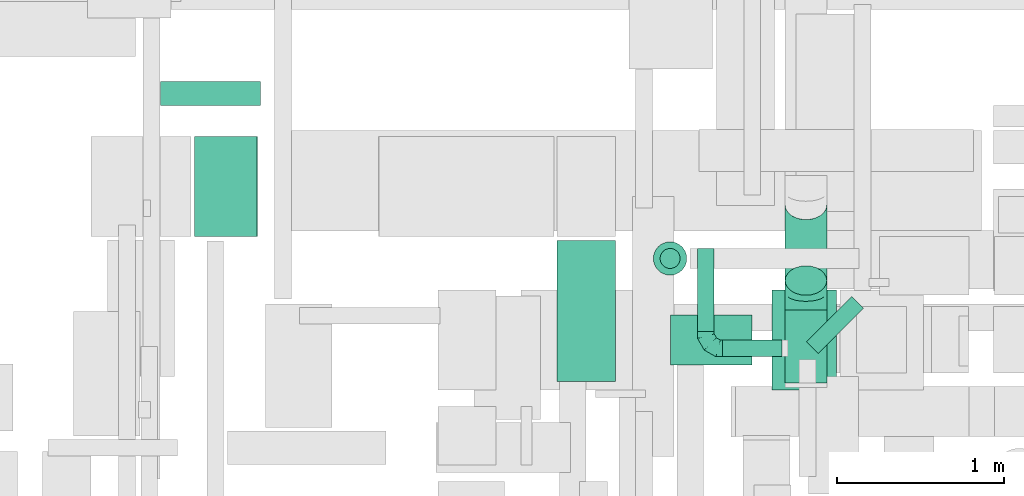
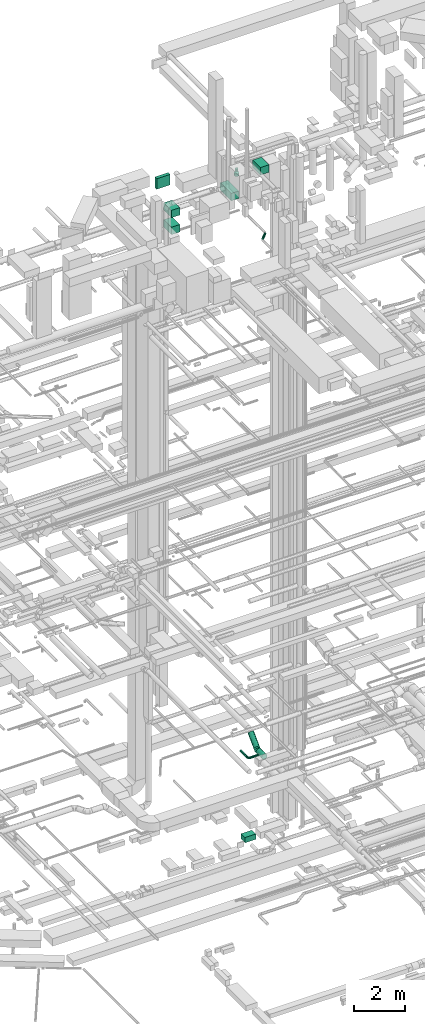
# One storey, part 137 of 337: 13 flow segments, 2 flow fittings.
"""IFC2X3 building model written with IfcOpenShell, lengths in millimetres."""

from ifc_helpers import new_model, entity, si_unit, converted_unit, derived_unit, direction, frame, origin, origin_2d_with_axis, place, context, subcontext, project, spatial, rectangle, circle, extrude, faceted_brep, source, transform, mapped, material, type_object, type_shapes, element, save


model = new_model("IFC2X3")

# Units and contexts
model_context = context("Model", 3, precision=0.01, world=origin(), true_north=direction((6.12303176911189e-17, 1.0)))
body_context = subcontext(model_context, "Body", "Model", "MODEL_VIEW")
ifc_project = project(units=[si_unit("LENGTHUNIT", "METRE", prefix="MILLI"), si_unit("AREAUNIT", "SQUARE_METRE"), si_unit("VOLUMEUNIT", "CUBIC_METRE"), converted_unit("PLANEANGLEUNIT", "DEGREE", entity("IfcRatioMeasure", 0.0174532925199433), si_unit("PLANEANGLEUNIT", "RADIAN"), dimensions=[0, 0, 0, 0, 0, 0, 0]), si_unit("MASSUNIT", "GRAM", prefix="KILO"), derived_unit("MASSDENSITYUNIT", [(si_unit("MASSUNIT", "GRAM", prefix="KILO"), 1), (si_unit("LENGTHUNIT", "METRE"), -3)]), derived_unit("MOMENTOFINERTIAUNIT", [(si_unit("LENGTHUNIT", "METRE"), 4)]), si_unit("TIMEUNIT", "SECOND"), si_unit("FREQUENCYUNIT", "HERTZ"), si_unit("THERMODYNAMICTEMPERATUREUNIT", "DEGREE_CELSIUS"), derived_unit("THERMALTRANSMITTANCEUNIT", [(si_unit("MASSUNIT", "GRAM", prefix="KILO"), 1), (si_unit("THERMODYNAMICTEMPERATUREUNIT", "KELVIN"), -1), (si_unit("TIMEUNIT", "SECOND"), -3)]), derived_unit("VOLUMETRICFLOWRATEUNIT", [(si_unit("LENGTHUNIT", "METRE"), 3), (si_unit("TIMEUNIT", "SECOND"), -1)]), derived_unit("MASSFLOWRATEUNIT", [(si_unit("MASSUNIT", "GRAM", prefix="KILO"), 1), (si_unit("TIMEUNIT", "SECOND"), -1)]), derived_unit("ROTATIONALFREQUENCYUNIT", [(si_unit("TIMEUNIT", "SECOND"), -1)]), si_unit("ELECTRICCURRENTUNIT", "AMPERE"), si_unit("ELECTRICVOLTAGEUNIT", "VOLT"), si_unit("POWERUNIT", "WATT"), si_unit("FORCEUNIT", "NEWTON", prefix="KILO"), si_unit("ILLUMINANCEUNIT", "LUX"), si_unit("LUMINOUSFLUXUNIT", "LUMEN"), si_unit("LUMINOUSINTENSITYUNIT", "CANDELA"), derived_unit("USERDEFINED", [(si_unit("MASSUNIT", "GRAM", prefix="KILO"), -1), (si_unit("LENGTHUNIT", "METRE"), -2), (si_unit("TIMEUNIT", "SECOND"), 3), (si_unit("LUMINOUSFLUXUNIT", "LUMEN"), 1)]), derived_unit("LINEARVELOCITYUNIT", [(si_unit("LENGTHUNIT", "METRE"), 1), (si_unit("TIMEUNIT", "SECOND"), -1)]), si_unit("PRESSUREUNIT", "PASCAL"), derived_unit("USERDEFINED", [(si_unit("LENGTHUNIT", "METRE"), -2), (si_unit("MASSUNIT", "GRAM", prefix="KILO"), 1), (si_unit("TIMEUNIT", "SECOND"), -2)]), derived_unit("LINEARFORCEUNIT", [(si_unit("MASSUNIT", "GRAM", prefix="KILO"), 1), (si_unit("LENGTHUNIT", "METRE"), 1), (si_unit("TIMEUNIT", "SECOND"), -2), (si_unit("LENGTHUNIT", "METRE"), -1)]), derived_unit("PLANARFORCEUNIT", [(si_unit("MASSUNIT", "GRAM", prefix="KILO"), 1), (si_unit("LENGTHUNIT", "METRE"), 1), (si_unit("TIMEUNIT", "SECOND"), -2), (si_unit("LENGTHUNIT", "METRE"), -2)])], contexts=[model_context])

# Site, building, storey
site_placement = place(None, origin())
site = spatial("IfcSite", under=ifc_project, at=site_placement, CompositionType="ELEMENT")
building_placement = place(site_placement, origin())
building = spatial("IfcBuilding", under=site, at=building_placement, CompositionType="ELEMENT")
storey_placement = place(building_placement, origin())
storey = spatial("IfcBuildingStorey", under=building, at=storey_placement, CompositionType="ELEMENT", Elevation=0.0)

# Flow segments
duct_segment_type_1 = type_object("IfcDuctSegmentType", PredefinedType="NOTDEFINED")
flow_segment_1_placement = place(storey_placement, frame((29050.12, 11895.06, -875.0)))
element("IfcFlowSegment", 1, at=flow_segment_1_placement, inside=storey, type_object=duct_segment_type_1, context=body_context, shape_type="SweptSolid", body=[
    extrude(rectangle(XDim=488.2844125, YDim=299.999999999999, at=origin_2d_with_axis()), frame((244.14, 150.0, 0.0), z_axis=(0.0, 0.0, 1.0), x_axis=(-1.0, 0.0, 0.0)), (0.0, 0.0, 1.0), 250.0),
])
flow_segment_2_placement = place(storey_placement, frame((26195.03, 12664.59, 29300.0)))
element("IfcFlowSegment", 2, at=flow_segment_2_placement, inside=storey, type_object=duct_segment_type_1, context=body_context, shape_type="SweptSolid", body=[
    extrude(rectangle(XDim=379.562915513085, YDim=600.0, at=origin_2d_with_axis()), frame((189.78, 300.0, 0.0)), (0.0, 0.0, 1.0), 349.999999999998),
])
flow_segment_3_placement = place(storey_placement, frame((26195.03, 12664.59, 28500.0)))
element("IfcFlowSegment", 3, at=flow_segment_3_placement, inside=storey, type_object=duct_segment_type_1, context=body_context, shape_type="SweptSolid", body=[
    extrude(rectangle(XDim=376.266500291202, YDim=600.0, at=origin_2d_with_axis()), frame((188.13, 300.0, 0.0)), (0.0, 0.0, 1.0), 349.999999999998),
])
duct_segment_type_2 = type_object("IfcDuctSegmentType", PredefinedType="NOTDEFINED")
flow_segment_4_placement = place(storey_placement, frame((29361.25, 11941.84, 2948.4)))
element("IfcFlowSegment", 4, at=flow_segment_4_placement, inside=storey, type_object=duct_segment_type_2, context=body_context, shape_type="SweptSolid", body=[
    extrude(circle(Radius=50.0, at=origin_2d_with_axis()), frame((0.0, 51.6, 51.6), z_axis=(1.0, 0.0, 0.0), x_axis=(0.0, -1.0, 0.0)), (0.0, 0.0, 1.0), 354.999999999971),
])
flow_segment_5_placement = place(storey_placement, frame((29209.66, 12093.44, 2948.4)))
element("IfcFlowSegment", 5, at=flow_segment_5_placement, inside=storey, type_object=duct_segment_type_2, context=body_context, shape_type="SweptSolid", body=[
    extrude(circle(Radius=50.0, at=origin_2d_with_axis()), frame((51.6, 0.0, 51.6), z_axis=(0.0, 1.0, 0.0), x_axis=(1.0, 0.0, 0.0)), (0.0, 0.0, 1.0), 500.000000000008),
])
flow_segment_6_placement = place(storey_placement, frame((29862.62, 11962.19, 27348.4)))
element("IfcFlowSegment", 6, at=flow_segment_6_placement, inside=storey, type_object=duct_segment_type_2, context=body_context, shape_type="SweptSolid", body=[
    extrude(circle(Radius=50.0, at=origin_2d_with_axis()), frame((36.95, 36.95, 51.6), z_axis=(0.707106781186565, 0.707106781186531, 0.0), x_axis=(-0.707106781186531, 0.707106781186565, 0.0)), (0.0, 0.0, 1.0), 383.01515190167),
])
flow_segment_7_placement = place(storey_placement, frame((28945.05, 12430.96, 30410.43)))
element("IfcFlowSegment", 7, at=flow_segment_7_placement, inside=storey, type_object=duct_segment_type_2, context=body_context, shape_type="SweptSolid", body=[
    extrude(circle(Radius=100.0, at=origin_2d_with_axis()), frame((101.6, 101.6, 0.0), z_axis=(0.0, 0.0, 1.0), x_axis=(0.0, 1.0, 0.0)), (0.0, 0.0, 1.0), 123.750000000002),
])
flow_segment_8_placement = place(storey_placement, frame((28985.05, 12470.96, 30614.18)))
element("IfcFlowSegment", 8, at=flow_segment_8_placement, inside=storey, type_object=duct_segment_type_2, context=body_context, shape_type="SweptSolid", body=[
    extrude(circle(Radius=60.0, at=origin_2d_with_axis()), frame((61.6, 61.6, 0.0), z_axis=(0.0, 0.0, 1.0), x_axis=(0.0, 1.0, 0.0)), (0.0, 0.0, 1.0), 117.893020611291),
])
flow_segment_9_placement = place(storey_placement, frame((29734.66, 12310.43, 2983.24)))
element("IfcFlowSegment", 9, at=flow_segment_9_placement, inside=storey, type_object=duct_segment_type_2, context=body_context, shape_type="SweptSolid", body=[
    extrude(circle(Radius=125.0, at=origin_2d_with_axis()), frame((126.6, 89.98, 89.98), z_axis=(0.0, 0.707106781186548, 0.707106781186548), x_axis=(-1.0, 0.0, 0.0)), (0.0, 0.0, 1.0), 641.421356237181),
])
flow_segment_10_placement = place(storey_placement, frame((29734.66, 11784.96, 2873.4)))
element("IfcFlowSegment", 10, at=flow_segment_10_placement, inside=storey, type_object=duct_segment_type_2, context=body_context, shape_type="SweptSolid", body=[
    extrude(circle(Radius=125.0, at=origin_2d_with_axis()), frame((126.6, 0.0, 126.6), z_axis=(0.0, 1.0, 0.0), x_axis=(-1.0, 0.0, 0.0)), (0.0, 0.0, 1.0), 438.674825475351),
])
duct_segment_type_3 = type_object("IfcDuctSegmentType", PredefinedType="NOTDEFINED")
flow_segment_11_placement = place(storey_placement, frame((25992.03, 13448.57, 30250.0)))
element("IfcFlowSegment", 11, at=flow_segment_11_placement, inside=storey, type_object=duct_segment_type_3, context=body_context, shape_type="SweptSolid", body=[
    extrude(rectangle(XDim=144.171519999918, YDim=599.999999999998, at=origin_2d_with_axis()), frame((300.0, 72.09, 0.0), z_axis=(0.0, 0.0, 1.0), x_axis=(0.0, -1.0, 0.0)), (0.0, 0.0, 1.0), 499.999999999999),
])
flow_segment_12_placement = place(storey_placement, frame((28370.03, 11795.06, 29870.0)))
element("IfcFlowSegment", 12, at=flow_segment_12_placement, inside=storey, type_object=duct_segment_type_3, context=body_context, shape_type="SweptSolid", body=[
    extrude(rectangle(XDim=844.533010000021, YDim=349.999999999998, at=origin_2d_with_axis()), frame((175.0, 422.27, 0.0), z_axis=(0.0, 0.0, 1.0), x_axis=(0.0, 1.0, 0.0)), (0.0, 0.0, 1.0), 349.999999999998),
])
flow_segment_13_placement = place(storey_placement, frame((29658.21, 11745.06, 30675.0)))
element("IfcFlowSegment", 13, at=flow_segment_13_placement, inside=storey, type_object=duct_segment_type_3, context=body_context, shape_type="SweptSolid", body=[
    extrude(rectangle(XDim=386.82034261461, YDim=600.0, at=origin_2d_with_axis()), frame((193.41, 300.0, 0.0)), (0.0, 0.0, 1.0), 349.999999999998),
])

# Flow fittings
ifc_material = material()
duct_fitting_type_1 = type_object("IfcDuctFittingType", PredefinedType="NOTDEFINED", material=ifc_material)
shared_shape_1 = source(origin(), body_context, "Body", "Brep", [
    faceted_brep([(-100.0, 0.0, -50.0), (-100.0, -12.94, -48.3), (-100.0, -25.0, -43.3), (-100.0, -35.36, -35.36), (-100.0, -43.3, -25.0), (-100.0, -48.3, -12.94), (-100.0, -50.0, 0.0), (-100.0, -48.3, 12.94), (-100.0, -43.3, 25.0), (-100.0, -35.36, 35.36), (-100.0, -25.0, 43.3), (-100.0, -12.94, 48.3), (-100.0, 0.0, 50.0), (-100.0, 12.94, 48.3), (-100.0, 25.0, 43.3), (-100.0, 35.36, 35.36), (-100.0, 43.3, 25.0), (-100.0, 48.3, 12.94), (-100.0, 50.0, 0.0), (-100.0, 48.3, -12.94), (-100.0, 43.3, -25.0), (-100.0, 35.36, -35.36), (-100.0, 25.0, -43.3), (-100.0, 12.94, -48.3), (-76.67, 12.94, 48.3), (-79.9, 25.0, 43.3), (-73.21, 0.0, 50.0), (-82.68, 35.36, 35.36), (-86.15, 48.3, 12.94), (-86.6, 50.0, 0.0), (-84.81, 43.3, 25.0), (-84.81, 43.3, -25.0), (-82.68, 35.36, -35.36), (-86.15, 48.3, -12.94), (-76.67, 12.94, -48.3), (-73.21, 0.0, -50.0), (-79.9, 25.0, -43.3), (-69.74, -12.94, -48.3), (-66.51, -25.0, -43.3), (-63.73, -35.36, -35.36), (-61.6, -43.3, -25.0), (-60.26, -48.3, -12.94), (-59.81, -50.0, 0.0), (-60.26, -48.3, 12.94), (-61.6, -43.3, 25.0), (-63.73, -35.36, 35.36), (-66.51, -25.0, 43.3), (-69.74, -12.94, 48.3), (-36.27, 36.27, 48.3), (-45.1, 45.1, 43.3), (-26.79, 26.79, 50.0), (-52.68, 52.68, 35.36), (-58.49, 58.49, 25.0), (-62.15, 62.15, 12.94), (-63.4, 63.4, 0.0), (-62.15, 62.15, -12.94), (-58.49, 58.49, -25.0), (-52.68, 52.68, -35.36), (-36.27, 36.27, -48.3), (-26.79, 26.79, -50.0), (-45.1, 45.1, -43.3), (-17.32, 17.32, -48.3), (-8.49, 8.49, -43.3), (-0.91, 0.91, -35.36), (4.9, -4.9, -25.0), (8.56, -8.56, -12.94), (9.81, -9.81, 0.0), (8.56, -8.56, 12.94), (4.9, -4.9, 25.0), (-0.91, 0.91, 35.36), (-8.49, 8.49, 43.3), (-17.32, 17.32, 48.3), (-12.94, 76.67, 48.3), (-25.0, 79.9, 43.3), (0.0, 73.21, 50.0), (-35.36, 82.68, 35.36), (-43.3, 84.81, 25.0), (-48.3, 86.15, 12.94), (-50.0, 86.6, 0.0), (-48.3, 86.15, -12.94), (-43.3, 84.81, -25.0), (-35.36, 82.68, -35.36), (-12.94, 76.67, -48.3), (0.0, 73.21, -50.0), (-25.0, 79.9, -43.3), (12.94, 69.74, -48.3), (25.0, 66.51, -43.3), (35.36, 63.73, -35.36), (43.3, 61.6, -25.0), (48.3, 60.26, -12.94), (50.0, 59.81, 0.0), (48.3, 60.26, 12.94), (43.3, 61.6, 25.0), (35.36, 63.73, 35.36), (25.0, 66.51, 43.3), (12.94, 69.74, 48.3), (-12.94, 100.0, -48.3), (-25.0, 100.0, -43.3), (-35.36, 100.0, -35.36), (-43.3, 100.0, -25.0), (-48.3, 100.0, -12.94), (-50.0, 100.0, 0.0), (-48.3, 100.0, 12.94), (-43.3, 100.0, 25.0), (-35.36, 100.0, 35.36), (-25.0, 100.0, 43.3), (-12.94, 100.0, 48.3), (0.0, 100.0, 50.0), (12.94, 100.0, 48.3), (25.0, 100.0, 43.3), (35.36, 100.0, 35.36), (43.3, 100.0, 25.0), (48.3, 100.0, 12.94), (50.0, 100.0, 0.0), (48.3, 100.0, -12.94), (43.3, 100.0, -25.0), (35.36, 100.0, -35.36), (25.0, 100.0, -43.3), (12.94, 100.0, -48.3), (0.0, 100.0, -50.0)], [[[0, 1, 2, 3, 4, 5, 6, 7, 8, 9, 10, 11, 12, 13, 14, 15, 16, 17, 18, 19, 20, 21, 22, 23]], [[24, 25, 14, 13]], [[26, 24, 13, 12]], [[14, 25, 27, 15]], [[28, 29, 18, 17]], [[30, 28, 17, 16]], [[15, 27, 30, 16]], [[20, 31, 32, 21]], [[33, 31, 20, 19]], [[18, 29, 33, 19]], [[34, 35, 0, 23]], [[36, 34, 23, 22]], [[32, 36, 22, 21]], [[2, 1, 37, 38]], [[3, 2, 38, 39]], [[0, 35, 37, 1]], [[5, 4, 40, 41]], [[6, 5, 41, 42]], [[3, 39, 40, 4]], [[6, 42, 43, 7]], [[7, 43, 44, 8]], [[8, 44, 45, 9]], [[10, 46, 47, 11]], [[11, 47, 26, 12]], [[10, 9, 45, 46]], [[48, 49, 25, 24]], [[50, 48, 24, 26]], [[27, 25, 49, 51]], [[52, 53, 28, 30]], [[51, 52, 30, 27]], [[29, 28, 53, 54]], [[55, 56, 31, 33]], [[54, 55, 33, 29]], [[57, 32, 31, 56]], [[58, 59, 35, 34]], [[60, 58, 34, 36]], [[57, 60, 36, 32]], [[37, 35, 59, 61]], [[38, 37, 61, 62]], [[39, 38, 62, 63]], [[41, 40, 64, 65]], [[42, 41, 65, 66]], [[63, 64, 40, 39]], [[43, 42, 66, 67]], [[44, 43, 67, 68]], [[68, 69, 45, 44]], [[46, 45, 69, 70]], [[47, 46, 70, 71]], [[26, 47, 71, 50]], [[72, 73, 49, 48]], [[74, 72, 48, 50]], [[51, 49, 73, 75]], [[76, 77, 53, 52]], [[75, 76, 52, 51]], [[54, 53, 77, 78]], [[79, 80, 56, 55]], [[78, 79, 55, 54]], [[81, 57, 56, 80]], [[82, 83, 59, 58]], [[84, 82, 58, 60]], [[81, 84, 60, 57]], [[61, 59, 83, 85]], [[62, 61, 85, 86]], [[63, 62, 86, 87]], [[65, 64, 88, 89]], [[66, 65, 89, 90]], [[87, 88, 64, 63]], [[67, 66, 90, 91]], [[68, 67, 91, 92]], [[92, 93, 69, 68]], [[70, 69, 93, 94]], [[71, 70, 94, 95]], [[50, 71, 95, 74]], [[96, 97, 98, 99, 100, 101, 102, 103, 104, 105, 106, 107, 108, 109, 110, 111, 112, 113, 114, 115, 116, 117, 118, 119]], [[72, 74, 107, 106]], [[73, 72, 106, 105]], [[75, 73, 105, 104]], [[77, 76, 103, 102]], [[78, 77, 102, 101]], [[75, 104, 103, 76]], [[78, 101, 100, 79]], [[79, 100, 99, 80]], [[80, 99, 98, 81]], [[96, 119, 83, 82]], [[97, 96, 82, 84]], [[84, 81, 98, 97]], [[83, 119, 118, 85]], [[85, 118, 117, 86]], [[86, 117, 116, 87]], [[88, 115, 114, 89]], [[89, 114, 113, 90]], [[87, 116, 115, 88]], [[91, 90, 113, 112]], [[92, 91, 112, 111]], [[93, 92, 111, 110]], [[95, 94, 109, 108]], [[74, 95, 108, 107]], [[110, 109, 94, 93]]]),
])
type_shapes(duct_fitting_type_1, [shared_shape_1])
flow_fitting_1_placement = place(storey_placement, frame((29261.25, 11993.44, 3000.0), z_axis=(0.0, 0.0, 1.0), x_axis=(0.0, -1.0, 0.0)))
element("IfcFlowFitting", 14, at=flow_fitting_1_placement, inside=storey, type_object=duct_fitting_type_1, material=ifc_material, context=body_context, shape_type="MappedRepresentation", body=[
    mapped(shared_shape_1, transform((0.0, 0.0, 0.0), scale=1.0)),
])
duct_fitting_type_2 = type_object("IfcDuctFittingType", PredefinedType="NOTDEFINED", material=ifc_material)
shared_shape_2 = source(origin(), body_context, "Body", "Brep", [
    faceted_brep([(-103.55, 0.0, -125.0), (-103.55, -32.35, -120.74), (-103.55, -62.5, -108.25), (-103.55, -88.39, -88.39), (-103.55, -108.25, -62.5), (-103.55, -120.74, -32.35), (-103.55, -125.0, 0.0), (-103.55, -120.74, 32.35), (-103.55, -108.25, 62.5), (-103.55, -88.39, 88.39), (-103.55, -62.5, 108.25), (-103.55, -32.35, 120.74), (-103.55, 0.0, 125.0), (-103.55, 32.35, 120.74), (-103.55, 62.5, 108.25), (-103.55, 88.39, 88.39), (-103.55, 108.25, 62.5), (-103.55, 120.74, 32.35), (-103.55, 125.0, 0.0), (-103.55, 120.74, -32.35), (-103.55, 108.25, -62.5), (-103.55, 88.39, -88.39), (-103.55, 62.5, -108.25), (-103.55, 32.35, -120.74), (-13.4, 32.35, 120.74), (-25.89, 62.5, 108.25), (0.0, 0.0, 125.0), (-36.61, 88.39, 88.39), (-44.84, 108.25, 62.5), (-50.01, 120.74, 32.35), (-51.78, 125.0, 0.0), (-50.01, 120.74, -32.35), (-44.84, 108.25, -62.5), (-36.61, 88.39, -88.39), (-13.4, 32.35, -120.74), (0.0, 0.0, -125.0), (-25.89, 62.5, -108.25), (13.4, -32.35, -120.74), (25.89, -62.5, -108.25), (36.61, -88.39, -88.39), (44.84, -108.25, -62.5), (50.01, -120.74, -32.35), (51.78, -125.0, 0.0), (50.01, -120.74, 32.35), (44.84, -108.25, 62.5), (36.61, -88.39, 88.39), (25.89, -62.5, 108.25), (13.4, -32.35, 120.74), (73.22, 73.22, 125.0), (50.35, 96.1, 120.74), (29.03, 117.42, 108.25), (10.72, 135.72, 88.39), (-3.32, 149.77, 62.5), (-12.15, 158.6, 32.35), (-15.17, 161.61, 0.0), (-12.15, 158.6, -32.35), (-3.32, 149.77, -62.5), (10.72, 135.72, -88.39), (29.03, 117.42, -108.25), (50.35, 96.1, -120.74), (73.22, 73.22, -125.0), (96.1, 50.35, -120.74), (117.42, 29.03, -108.25), (135.72, 10.72, -88.39), (149.77, -3.32, -62.5), (158.6, -12.15, -32.35), (161.61, -15.17, 0.0), (158.6, -12.15, 32.35), (149.77, -3.32, 62.5), (135.72, 10.72, 88.39), (117.42, 29.03, 108.25), (96.1, 50.35, 120.74)], [[[0, 1, 2, 3, 4, 5, 6, 7, 8, 9, 10, 11, 12, 13, 14, 15, 16, 17, 18, 19, 20, 21, 22, 23]], [[24, 25, 14, 13]], [[26, 24, 13, 12]], [[14, 25, 27, 15]], [[28, 29, 17, 16]], [[28, 16, 15, 27]], [[30, 18, 17, 29]], [[31, 32, 20, 19]], [[30, 31, 19, 18]], [[32, 33, 21, 20]], [[34, 35, 0, 23]], [[36, 34, 23, 22]], [[33, 36, 22, 21]], [[1, 0, 35, 37]], [[2, 1, 37, 38]], [[38, 39, 3, 2]], [[5, 4, 40, 41]], [[6, 5, 41, 42]], [[39, 40, 4, 3]], [[6, 42, 43, 7]], [[7, 43, 44, 8]], [[8, 44, 45, 9]], [[9, 45, 46, 10]], [[10, 46, 47, 11]], [[26, 12, 11, 47]], [[24, 26, 48, 49]], [[25, 24, 49, 50]], [[27, 25, 50, 51]], [[29, 28, 52, 53]], [[30, 29, 53, 54]], [[51, 52, 28, 27]], [[30, 54, 55, 31]], [[31, 55, 56, 32]], [[57, 33, 32, 56]], [[36, 58, 59, 34]], [[34, 59, 60, 35]], [[58, 36, 33, 57]], [[35, 60, 61, 37]], [[37, 61, 62, 38]], [[63, 39, 38, 62]], [[40, 64, 65, 41]], [[41, 65, 66, 42]], [[64, 40, 39, 63]], [[43, 42, 66, 67]], [[44, 43, 67, 68]], [[68, 69, 45, 44]], [[47, 46, 70, 71]], [[26, 47, 71, 48]], [[69, 70, 46, 45]], [[59, 58, 57, 56, 55, 54, 53, 52, 51, 50, 49, 48, 71, 70, 69, 68, 67, 66, 65, 64, 63, 62, 61, 60]]]),
])
type_shapes(duct_fitting_type_2, [shared_shape_2])
flow_fitting_2_placement = place(storey_placement, frame((29861.25, 12327.19, 3000.0), z_axis=(-1.0, 0.0, 0.0), x_axis=(0.0, -0.707106781186476, -0.70710678118662)))
element("IfcFlowFitting", 15, at=flow_fitting_2_placement, inside=storey, type_object=duct_fitting_type_2, material=ifc_material, context=body_context, shape_type="MappedRepresentation", body=[
    mapped(shared_shape_2, transform((0.0, 0.0, 0.0), scale=1.0)),
])

save(model, "model.ifc")
